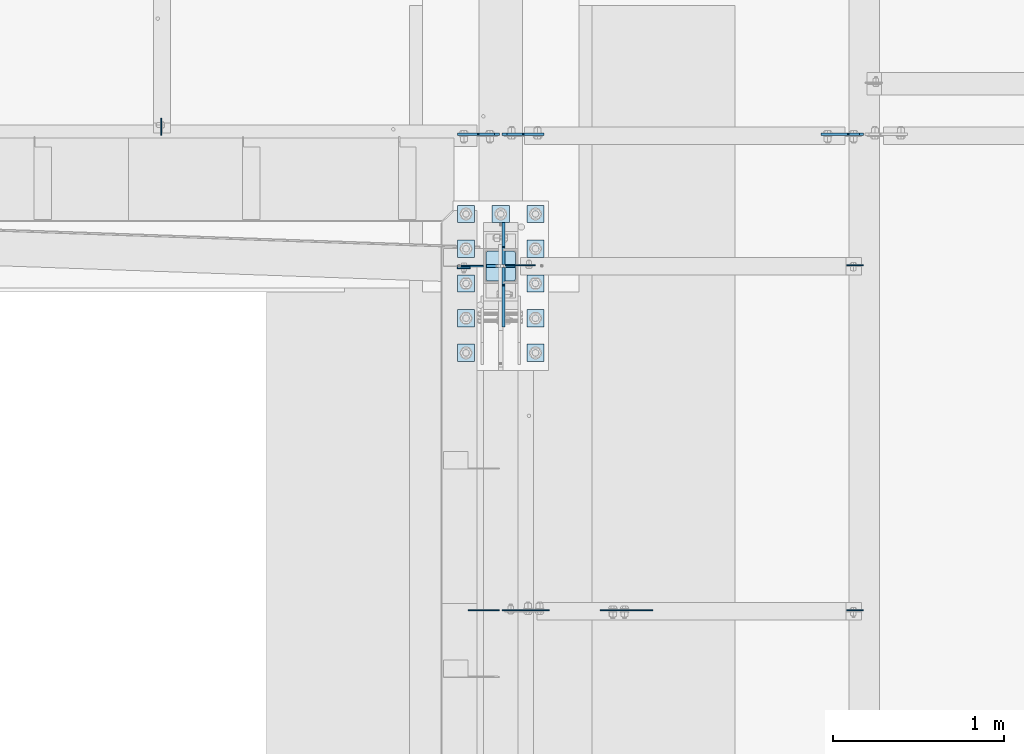
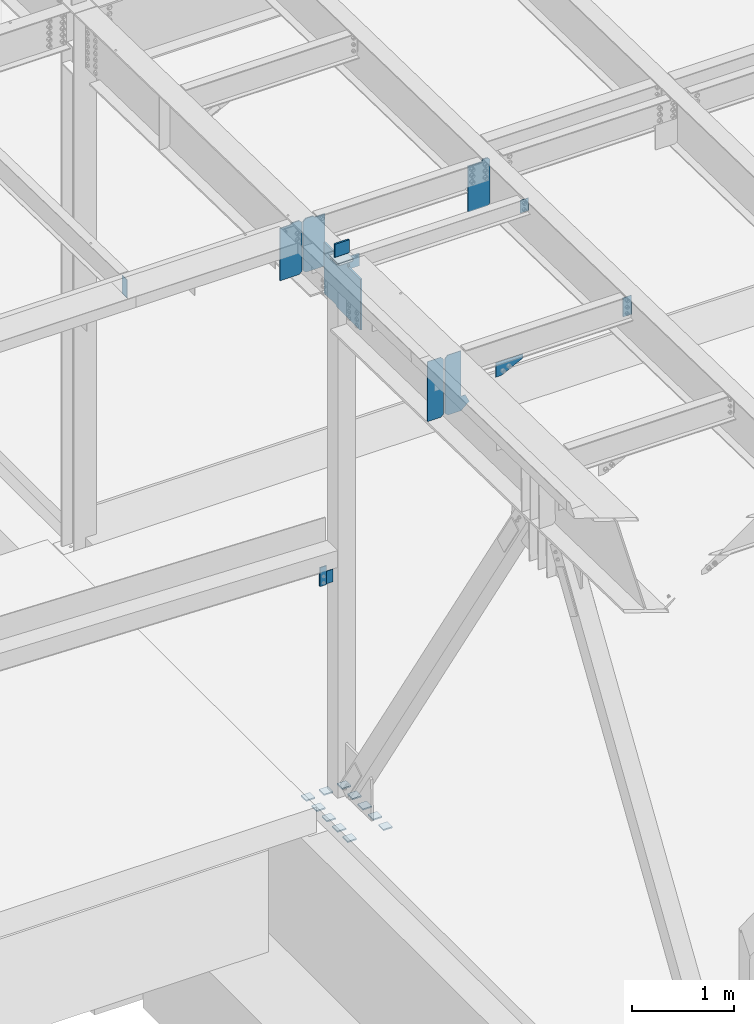
# One storey, part 1437 of 1763: 26 plates, 8 elements without a shape of their own.
"""IFC2X3 building model written with IfcOpenShell, lengths in millimetres."""

from ifc_helpers import new_model, si_unit, frame, origin_with_axes, place, context, subcontext, project, spatial, faceted_brep, material, type_object, element, aggregate, save


model = new_model("IFC2X3")

# Units and contexts
model_context = context("Model", 3, precision=1e-05, world=origin_with_axes())
body_context = subcontext(model_context, "Body", "Model", "MODEL_VIEW")
ifc_project = project(units=[si_unit("LENGTHUNIT", "METRE", prefix="MILLI"), si_unit("AREAUNIT", "SQUARE_METRE"), si_unit("VOLUMEUNIT", "CUBIC_METRE"), si_unit("MASSUNIT", "GRAM", prefix="KILO"), si_unit("TIMEUNIT", "SECOND"), si_unit("PLANEANGLEUNIT", "RADIAN"), si_unit("SOLIDANGLEUNIT", "STERADIAN"), si_unit("THERMODYNAMICTEMPERATUREUNIT", "DEGREE_CELSIUS"), si_unit("LUMINOUSINTENSITYUNIT", "LUMEN")], contexts=[model_context])

# Site, building, storey
site_placement = place(None, origin_with_axes())
site = spatial("IfcSite", under=ifc_project, at=site_placement, CompositionType="ELEMENT")
building_placement = place(site_placement, origin_with_axes())
building = spatial("IfcBuilding", under=site, at=building_placement, Name="Undefined", CompositionType="ELEMENT")
storey_placement = place(building_placement, origin_with_axes())
storey = spatial("IfcBuildingStorey", under=building, at=storey_placement, Name="Undefined", CompositionType="ELEMENT", Elevation=0.0)

# Assembly, plates
assembly_1_placement = place(storey_placement, origin_with_axes())
assembly_1 = element("IfcElementAssembly", 1, at=assembly_1_placement, inside=storey, Name="BEAM", AssemblyPlace="NOTDEFINED", PredefinedType="RIGID_FRAME")
ifc_material_1 = material(Name="STEEL/A36")
plate_type_1 = type_object("IfcPlateType", PredefinedType="NOTDEFINED")
plate_1_placement = place(assembly_1_placement, frame((-85253.8569165555, 8539.95625000002, 11685.5045365056), z_axis=(-1.0, 0.0, 0.0), x_axis=(0.0, 0.0, -1.0)))
plate_1 = element("IfcPlate", 2, at=plate_1_placement, type_object=plate_type_1, material=ifc_material_1, Name="PLATE", context=body_context, shape_type="Brep", body=[
    faceted_brep([(1.81898940354586e-12, -3.17500000000291, 0.0), (0.0, -3.17499999999927, 96.8375015258789), (0.0, 3.17499999999927, 96.8375015258789), (-1.81898940354586e-12, 3.17499999997381, 0.0), (152.399993896484, -3.17499999999927, 96.8375015258789), (152.399993896484, 3.17499999999927, 96.8375015258789), (152.399993896484, -3.17500000000291, 0.0), (152.399993896484, 3.17500000000291, 0.0)], [[[0, 1, 2, 3]], [[1, 4, 5, 2]], [[4, 6, 7, 5]], [[6, 0, 3, 7]], [[5, 7, 3, 2]], [[6, 4, 1, 0]]]),
])
plate_2_placement = place(assembly_1_placement, frame((-85253.8569165555, 6521.44999998666, 11743.6501802739), z_axis=(-1.0, 0.0, 0.0), x_axis=(0.0, 0.0, -1.0)))
plate_2 = element("IfcPlate", 3, at=plate_2_placement, type_object=plate_type_1, material=ifc_material_1, Name="PLATE", context=body_context, shape_type="Brep", body=[
    faceted_brep([(1.81898940354586e-12, -3.17500000000291, 0.0), (0.0, -3.17499999999927, 96.8375015258789), (0.0, 3.17499999999927, 96.8375015258789), (-1.81898940354586e-12, 3.17499999997381, 0.0), (228.600006103516, -3.17499999999927, 96.8375015258789), (228.600006103516, 3.17499999999927, 96.8375015258789), (228.600006103516, -3.17500000001019, -7.27595761418343e-12), (228.600006103516, 3.17499999999563, -7.27595761418343e-12)], [[[0, 1, 2, 3]], [[1, 4, 5, 2]], [[4, 6, 7, 5]], [[6, 0, 3, 7]], [[5, 7, 3, 2]], [[6, 4, 1, 0]]]),
])

# Assembly, plate
assembly_2_placement = place(storey_placement, origin_with_axes())
assembly_2 = element("IfcElementAssembly", 4, at=assembly_2_placement, inside=storey, Name="BEAM", AssemblyPlace="NOTDEFINED", PredefinedType="RIGID_FRAME")
plate_type_2 = type_object("IfcPlateType", PredefinedType="NOTDEFINED")
plate_3_placement = place(assembly_2_placement, frame((-87553.2372858673, 8524.87499837763, 8096.24999389648), z_axis=(0.0, 0.0, -1.0), x_axis=(-1.0, 0.0, 0.0)))
plate_3 = element("IfcPlate", 5, at=plate_3_placement, type_object=plate_type_2, material=ifc_material_1, Name="PLATE", context=body_context, shape_type="Brep", body=[
    faceted_brep([(0.0, -4.76249999999982, 0.0), (-2.83762346953154e-10, -4.7624999996915, 228.600006103516), (-2.83762346953154e-10, 4.76250000028813, 228.600006103517), (0.0, 4.76249999999982, 0.0), (76.1999969480166, -4.76249999961874, 228.600006103516), (76.1999969480166, 4.76250000036089, 228.600006103517), (76.1999969482931, -4.76249999991705, 0.0), (76.1999969482931, 4.76250000006257, 1.81898940354586e-12)], [[[0, 1, 2, 3]], [[1, 4, 5, 2]], [[4, 6, 7, 5]], [[6, 0, 3, 7]], [[5, 7, 3, 2]], [[6, 4, 1, 0]]]),
])
aggregate(assembly_2, [plate_3])

assembly_3_placement = place(storey_placement, origin_with_axes())
assembly_3 = element("IfcElementAssembly", 6, at=assembly_3_placement, inside=storey, Name="COLUMN", AssemblyPlace="NOTDEFINED", PredefinedType="RIGID_FRAME")
plate_type_3 = type_object("IfcPlateType", PredefinedType="NOTDEFINED")
plate_4_placement = place(assembly_3_placement, frame((-87629.4372828536, 8534.39999695398, 7867.64998779296), z_axis=(0.0, 0.0, 1.0), x_axis=(1.0, 0.0, 0.0)))
plate_4 = element("IfcPlate", 7, at=plate_4_placement, type_object=plate_type_3, material=ifc_material_1, Name="PLATE", context=body_context, shape_type="Brep", body=[
    faceted_brep([(0.0, -4.76249999999982, 0.0), (-3.05175672110636e-06, -4.7625000002663, 152.399993896484), (-3.05175490211695e-06, 4.76249999972788, 152.399993896484), (0.0, 4.76249999999982, 0.0), (152.400009155272, -4.76249999975698, 152.399993896484), (152.400009155273, 4.76250000024447, 152.399993896484), (152.400009155272, -4.76249999948777, 5.45696821063757e-12), (152.400009155273, 4.76250000051368, 3.63797880709171e-12)], [[[0, 1, 2, 3]], [[1, 4, 5, 2]], [[4, 6, 7, 5]], [[6, 0, 3, 7]], [[5, 7, 3, 2]], [[6, 4, 1, 0]]]),
])

# Assembly, plates
assembly_4_placement = place(storey_placement, origin_with_axes())
assembly_4 = element("IfcElementAssembly", 8, at=assembly_4_placement, inside=storey, Name="TEMPLATE", AssemblyPlace="NOTDEFINED", PredefinedType="RIGID_FRAME")
plate_type_4 = type_object("IfcPlateType", PredefinedType="NOTDEFINED")
plate_5_placement = place(assembly_4_placement, frame((-87527.8372736983, 8077.20000000001, 5138.73750000001), z_axis=(-1.0, 0.0, 0.0), x_axis=(0.0, -1.0, 0.0)))
plate_5 = element("IfcPlate", 9, at=plate_5_placement, type_object=plate_type_4, material=ifc_material_1, Name="WASHER PLATE", context=body_context, shape_type="Brep", body=[
    faceted_brep([(-7.27595761418343e-12, -7.9375, 0.0), (0.0, -7.9375, 101.599998474121), (0.0, 7.9375, 101.599998474121), (-7.27595761418343e-12, 7.9375, 0.0), (101.599998474121, -7.9375, 101.599998474121), (101.599998474121, 7.9375, 101.599998474121), (101.599998474121, -7.9375, 0.0), (101.599998474121, 7.9375, 0.0)], [[[0, 1, 2, 3]], [[1, 4, 5, 2]], [[4, 6, 7, 5]], [[6, 0, 3, 7]], [[5, 7, 3, 2]], [[6, 4, 1, 0]]]),
])
plate_6_placement = place(assembly_4_placement, frame((-87121.4372736983, 8077.20000000001, 5138.73750000001), z_axis=(-1.0, 0.0, 0.0), x_axis=(0.0, -1.0, 0.0)))
plate_6 = element("IfcPlate", 10, at=plate_6_placement, type_object=plate_type_4, material=ifc_material_1, Name="WASHER PLATE", context=body_context, shape_type="Brep", body=[
    faceted_brep([(-7.27595761418343e-12, -7.9375, 0.0), (0.0, -7.9375, 101.599998474121), (0.0, 7.9375, 101.599998474121), (-7.27595761418343e-12, 7.9375, 0.0), (101.599998474121, -7.9375, 101.599998474121), (101.599998474121, 7.9375, 101.599998474121), (101.599998474121, -7.9375, 0.0), (101.599998474121, 7.9375, 0.0)], [[[0, 1, 2, 3]], [[1, 4, 5, 2]], [[4, 6, 7, 5]], [[6, 0, 3, 7]], [[5, 7, 3, 2]], [[6, 4, 1, 0]]]),
])
plate_7_placement = place(assembly_4_placement, frame((-87527.8372736983, 8280.40000000001, 5138.73750000001), z_axis=(-1.0, 0.0, 0.0), x_axis=(0.0, -1.0, 0.0)))
plate_7 = element("IfcPlate", 11, at=plate_7_placement, type_object=plate_type_4, material=ifc_material_1, Name="WASHER PLATE", context=body_context, shape_type="Brep", body=[
    faceted_brep([(-7.27595761418343e-12, -7.9375, 0.0), (0.0, -7.9375, 101.599998474121), (0.0, 7.9375, 101.599998474121), (-7.27595761418343e-12, 7.9375, 0.0), (101.599998474121, -7.9375, 101.599998474121), (101.599998474121, 7.9375, 101.599998474121), (101.599998474121, -7.9375, 0.0), (101.599998474121, 7.9375, 0.0)], [[[0, 1, 2, 3]], [[1, 4, 5, 2]], [[4, 6, 7, 5]], [[6, 0, 3, 7]], [[5, 7, 3, 2]], [[6, 4, 1, 0]]]),
])
plate_8_placement = place(assembly_4_placement, frame((-87121.4372736983, 8280.40000000001, 5138.73750000001), z_axis=(-1.0, 0.0, 0.0), x_axis=(0.0, -1.0, 0.0)))
plate_8 = element("IfcPlate", 12, at=plate_8_placement, type_object=plate_type_4, material=ifc_material_1, Name="WASHER PLATE", context=body_context, shape_type="Brep", body=[
    faceted_brep([(-7.27595761418343e-12, -7.9375, 0.0), (0.0, -7.9375, 101.599998474121), (0.0, 7.9375, 101.599998474121), (-7.27595761418343e-12, 7.9375, 0.0), (101.599998474121, -7.9375, 101.599998474121), (101.599998474121, 7.9375, 101.599998474121), (101.599998474121, -7.9375, 0.0), (101.599998474121, 7.9375, 0.0)], [[[0, 1, 2, 3]], [[1, 4, 5, 2]], [[4, 6, 7, 5]], [[6, 0, 3, 7]], [[5, 7, 3, 2]], [[6, 4, 1, 0]]]),
])
plate_9_placement = place(assembly_4_placement, frame((-87527.8372736983, 8483.60000000001, 5138.73750000001), z_axis=(-1.0, 0.0, 0.0), x_axis=(0.0, -1.0, 0.0)))
plate_9 = element("IfcPlate", 13, at=plate_9_placement, type_object=plate_type_4, material=ifc_material_1, Name="WASHER PLATE", context=body_context, shape_type="Brep", body=[
    faceted_brep([(-7.27595761418343e-12, -7.9375, 0.0), (0.0, -7.9375, 101.599998474121), (0.0, 7.9375, 101.599998474121), (-7.27595761418343e-12, 7.9375, 0.0), (101.599998474121, -7.9375, 101.599998474121), (101.599998474121, 7.9375, 101.599998474121), (101.599998474121, -7.9375, 0.0), (101.599998474121, 7.9375, 0.0)], [[[0, 1, 2, 3]], [[1, 4, 5, 2]], [[4, 6, 7, 5]], [[6, 0, 3, 7]], [[5, 7, 3, 2]], [[6, 4, 1, 0]]]),
])
plate_10_placement = place(assembly_4_placement, frame((-87121.4372736983, 8483.60000000001, 5138.73750000001), z_axis=(-1.0, 0.0, 0.0), x_axis=(0.0, -1.0, 0.0)))
plate_10 = element("IfcPlate", 14, at=plate_10_placement, type_object=plate_type_4, material=ifc_material_1, Name="WASHER PLATE", context=body_context, shape_type="Brep", body=[
    faceted_brep([(-7.27595761418343e-12, -7.9375, 0.0), (0.0, -7.9375, 101.599998474121), (0.0, 7.9375, 101.599998474121), (-7.27595761418343e-12, 7.9375, 0.0), (101.599998474121, -7.9375, 101.599998474121), (101.599998474121, 7.9375, 101.599998474121), (101.599998474121, -7.9375, 0.0), (101.599998474121, 7.9375, 0.0)], [[[0, 1, 2, 3]], [[1, 4, 5, 2]], [[4, 6, 7, 5]], [[6, 0, 3, 7]], [[5, 7, 3, 2]], [[6, 4, 1, 0]]]),
])
plate_11_placement = place(assembly_4_placement, frame((-87527.8372736983, 8686.80000000001, 5138.73750000001), z_axis=(-1.0, 0.0, 0.0), x_axis=(0.0, -1.0, 0.0)))
plate_11 = element("IfcPlate", 15, at=plate_11_placement, type_object=plate_type_4, material=ifc_material_1, Name="WASHER PLATE", context=body_context, shape_type="Brep", body=[
    faceted_brep([(-7.27595761418343e-12, -7.9375, 0.0), (0.0, -7.9375, 101.599998474121), (0.0, 7.9375, 101.599998474121), (-7.27595761418343e-12, 7.9375, 0.0), (101.599998474121, -7.9375, 101.599998474121), (101.599998474121, 7.9375, 101.599998474121), (101.599998474121, -7.9375, 0.0), (101.599998474121, 7.9375, 0.0)], [[[0, 1, 2, 3]], [[1, 4, 5, 2]], [[4, 6, 7, 5]], [[6, 0, 3, 7]], [[5, 7, 3, 2]], [[6, 4, 1, 0]]]),
])
plate_12_placement = place(assembly_4_placement, frame((-87121.4372736983, 8686.80000000001, 5138.73750000001), z_axis=(-1.0, 0.0, 0.0), x_axis=(0.0, -1.0, 0.0)))
plate_12 = element("IfcPlate", 16, at=plate_12_placement, type_object=plate_type_4, material=ifc_material_1, Name="WASHER PLATE", context=body_context, shape_type="Brep", body=[
    faceted_brep([(-7.27595761418343e-12, -7.9375, 0.0), (0.0, -7.9375, 101.599998474121), (0.0, 7.9375, 101.599998474121), (-7.27595761418343e-12, 7.9375, 0.0), (101.599998474121, -7.9375, 101.599998474121), (101.599998474121, 7.9375, 101.599998474121), (101.599998474121, -7.9375, 0.0), (101.599998474121, 7.9375, 0.0)], [[[0, 1, 2, 3]], [[1, 4, 5, 2]], [[4, 6, 7, 5]], [[6, 0, 3, 7]], [[5, 7, 3, 2]], [[6, 4, 1, 0]]]),
])
plate_13_placement = place(assembly_4_placement, frame((-87527.8372736983, 8890.00000000001, 5138.73750000001), z_axis=(-1.0, 0.0, 0.0), x_axis=(0.0, -1.0, 0.0)))
plate_13 = element("IfcPlate", 17, at=plate_13_placement, type_object=plate_type_4, material=ifc_material_1, Name="WASHER PLATE", context=body_context, shape_type="Brep", body=[
    faceted_brep([(-7.27595761418343e-12, -7.9375, 0.0), (0.0, -7.9375, 101.599998474121), (0.0, 7.9375, 101.599998474121), (-7.27595761418343e-12, 7.9375, 0.0), (101.599998474121, -7.9375, 101.599998474121), (101.599998474121, 7.9375, 101.599998474121), (101.599998474121, -7.9375, 0.0), (101.599998474121, 7.9375, 0.0)], [[[0, 1, 2, 3]], [[1, 4, 5, 2]], [[4, 6, 7, 5]], [[6, 0, 3, 7]], [[5, 7, 3, 2]], [[6, 4, 1, 0]]]),
])
plate_14_placement = place(assembly_4_placement, frame((-87324.6372736983, 8890.00000000001, 5138.73750000001), z_axis=(-1.0, 0.0, 0.0), x_axis=(0.0, -1.0, 0.0)))
plate_14 = element("IfcPlate", 18, at=plate_14_placement, type_object=plate_type_4, material=ifc_material_1, Name="WASHER PLATE", context=body_context, shape_type="Brep", body=[
    faceted_brep([(-7.27595761418343e-12, -7.9375, 0.0), (0.0, -7.9375, 101.599998474121), (0.0, 7.9375, 101.599998474121), (-7.27595761418343e-12, 7.9375, 0.0), (101.599998474121, -7.9375, 101.599998474121), (101.599998474121, 7.9375, 101.599998474121), (101.599998474121, -7.9375, 0.0), (101.599998474121, 7.9375, 0.0)], [[[0, 1, 2, 3]], [[1, 4, 5, 2]], [[4, 6, 7, 5]], [[6, 0, 3, 7]], [[5, 7, 3, 2]], [[6, 4, 1, 0]]]),
])
plate_15_placement = place(assembly_4_placement, frame((-87121.4372736983, 8890.00000000001, 5138.73750000001), z_axis=(-1.0, 0.0, 0.0), x_axis=(0.0, -1.0, 0.0)))
plate_15 = element("IfcPlate", 19, at=plate_15_placement, type_object=plate_type_4, material=ifc_material_1, Name="WASHER PLATE", context=body_context, shape_type="Brep", body=[
    faceted_brep([(-7.27595761418343e-12, -7.9375, 0.0), (0.0, -7.9375, 101.599998474121), (0.0, 7.9375, 101.599998474121), (-7.27595761418343e-12, 7.9375, 0.0), (101.599998474121, -7.9375, 101.599998474121), (101.599998474121, 7.9375, 101.599998474121), (101.599998474121, -7.9375, 0.0), (101.599998474121, 7.9375, 0.0)], [[[0, 1, 2, 3]], [[1, 4, 5, 2]], [[4, 6, 7, 5]], [[6, 0, 3, 7]], [[5, 7, 3, 2]], [[6, 4, 1, 0]]]),
])
aggregate(assembly_4, [plate_5, plate_6, plate_7, plate_8, plate_9, plate_10, plate_11, plate_12, plate_13, plate_14, plate_15])

# Plate
ifc_material_2 = material(Name="STEEL/A572-50")
plate_type_5 = type_object("IfcPlateType", PredefinedType="NOTDEFINED")
plate_16_placement = place(assembly_3_placement, frame((-87292.8872736984, 8534.40000000001, 11904.6348438825), z_axis=(0.0, 0.0, -1.0), x_axis=(-1.0, 0.0, 0.0)))
plate_16 = element("IfcPlate", 20, at=plate_16_placement, type_object=plate_type_5, material=ifc_material_2, Name="PLATE", context=body_context, shape_type="Brep", body=[
    faceted_brep([(7.27595761418343e-12, 9.52500000000146, 155.574990844727), (-1.45519152283669e-11, 7.27595761418343e-12, 165.099990844727), (165.099990844727, 0.0, 165.099990844727), (165.099990844727, 9.52500000000146, 155.574990844727), (-3.63797880709171e-11, -9.5249999999869, 155.574990844727), (165.099990844727, -9.52500000000146, 155.574990844727), (0.0, 9.52500000000146, 0.0), (0.0, -9.52500000000146, 0.0), (165.099990844727, -9.52500000000146, 0.0), (165.099990844727, 9.52500000000146, 0.0)], [[[0, 1, 2, 3]], [[1, 4, 5, 2]], [[6, 7, 4, 1, 0]], [[5, 8, 9, 3, 2]], [[8, 7, 6, 9]], [[9, 6, 0, 3]], [[7, 8, 5, 4]]]),
])

# Assembly, plate
assembly_5_placement = place(storey_placement, origin_with_axes())
assembly_5 = element("IfcElementAssembly", 21, at=assembly_5_placement, inside=storey, Name="BEAM", AssemblyPlace="NOTDEFINED", PredefinedType="RIGID_FRAME")
plate_type_6 = type_object("IfcPlateType", PredefinedType="NOTDEFINED")
plate_17_placement = place(assembly_5_placement, frame((-89362.1935236984, 9299.575, 11677.8342065501), z_axis=(0.0, 1.0, 0.0), x_axis=(0.0, 0.0, -1.0)))
plate_17 = element("IfcPlate", 22, at=plate_17_placement, type_object=plate_type_6, material=ifc_material_1, Name="PLATE", context=body_context, shape_type="Brep", body=[
    faceted_brep([(1.81898940354586e-12, -3.17500000000291, 0.0), (-2.52839527092874e-10, -3.17500000000001, 98.4250000002357), (4.17785486206412e-08, 3.17500000000001, 98.425000000243), (-1.81898940354586e-12, 3.17499999997381, 0.0), (215.899993896484, -3.17500000000291, 98.4250030517578), (215.899993896484, 3.17500000000291, 98.4250030517578), (215.899993896484, -3.17500000000291, 0.0), (215.899993896484, 3.17500000000291, 0.0)], [[[0, 1, 2, 3]], [[1, 4, 5, 2]], [[4, 6, 7, 5]], [[6, 0, 3, 7]], [[5, 7, 3, 2]], [[6, 4, 1, 0]]]),
])
aggregate(assembly_5, [plate_17])

# Assembly, plates
assembly_6_placement = place(storey_placement, origin_with_axes())
assembly_6 = element("IfcElementAssembly", 23, at=assembly_6_placement, inside=storey, Name="BEAM", AssemblyPlace="NOTDEFINED", PredefinedType="RIGID_FRAME")
plate_type_7 = type_object("IfcPlateType", PredefinedType="NOTDEFINED")
plate_18_placement = place(assembly_6_placement, frame((-87383.6747736984, 6521.45000003568, 11035.6954250997), z_axis=(0.0, 0.0, 1.0), x_axis=(-1.0, 0.0, 0.0)))
plate_18 = element("IfcPlate", 24, at=plate_18_placement, type_object=plate_type_7, material=ifc_material_1, Name="PLATE", context=body_context, shape_type="Brep", body=[
    faceted_brep([(0.0, -3.17500000000291, 31.75), (0.0, -3.17499999999927, 686.812194824219), (0.0, 3.17499999999927, 686.812194824219), (0.0, 3.17500000000291, 31.75), (31.75, -3.17499999999927, 718.562194824219), (31.75, 3.17499999999927, 718.562194824219), (182.5625, -3.17499999999927, 718.562194824219), (182.5625, 3.17499999999927, 718.562194824219), (182.5625, -3.17500000000291, 0.0), (182.5625, 3.17500000000291, 0.0), (31.7499999999036, -3.17499999997381, 9.42916855706244e-11), (31.7499999998854, 3.17500000000291, 9.42916855706244e-11)], [[[0, 1, 2, 3]], [[1, 4, 5, 2]], [[4, 6, 7, 5]], [[6, 8, 9, 7]], [[8, 10, 11, 9]], [[10, 0, 3, 11]], [[5, 7, 9, 11, 3, 2]], [[10, 8, 6, 4, 1, 0]]]),
])
plate_type_8 = type_object("IfcPlateType", PredefinedType="NOTDEFINED")
plate_19_placement = place(assembly_6_placement, frame((-87367.1997736983, 6521.4500000346, 11035.6954250997), z_axis=(0.0, 0.0, 1.0), x_axis=(1.0, 0.0, 0.0)))
plate_19 = element("IfcPlate", 25, at=plate_19_placement, type_object=plate_type_8, material=ifc_material_1, Name="PLATE", context=body_context, shape_type="Brep", body=[
    faceted_brep([(0.0, -3.17500000000291, 31.75), (0.0, -3.17499999999927, 686.812255859375), (0.0, 3.17499999999927, 686.812255859375), (0.0, 3.17500000000291, 31.75), (31.75, -3.17499999999927, 718.562255859375), (31.75, 3.17499999999927, 718.562255859375), (182.5625, -3.17500000000018, 718.562255859375), (182.5625, 3.17500000000018, 718.562255859375), (182.261993408203, -3.17499999999927, 172.454345703125), (182.261993408203, 3.17499999999927, 172.454345703125), (230.306228637695, -3.17499999999927, 172.454345703125), (230.306228637695, 3.17499999999927, 172.454345703125), (275.743133544922, -3.17499999999927, 81.5805358886719), (275.743133544922, 3.17499999999927, 81.5805358886719), (182.262496948242, -3.17500000000018, 0.0), (182.262496948242, 3.17500000000018, 0.0), (31.7499999999036, -3.17499999997381, 9.42916855706244e-11), (31.7499999998854, 3.17500000000291, 9.42916855706244e-11)], [[[0, 1, 2, 3]], [[1, 4, 5, 2]], [[4, 6, 7, 5]], [[6, 8, 9, 7]], [[8, 10, 11, 9]], [[10, 12, 13, 11]], [[12, 14, 15, 13]], [[14, 16, 17, 15]], [[16, 0, 3, 17]], [[5, 7, 9, 11, 13, 15, 17, 3, 2]], [[16, 14, 12, 10, 8, 6, 4, 1, 0]]]),
])
aggregate(assembly_6, [plate_18, plate_19])

# Assembly, plate
assembly_7_placement = place(storey_placement, origin_with_axes())
assembly_7 = element("IfcElementAssembly", 26, at=assembly_7_placement, inside=storey, Name="BEAM", AssemblyPlace="NOTDEFINED", PredefinedType="RIGID_FRAME")
plate_type_9 = type_object("IfcPlateType", PredefinedType="NOTDEFINED")
plate_20_placement = place(assembly_7_placement, frame((-86792.4786752764, 6521.44999998672, 11470.6001802778), z_axis=(1.0, 0.0, 0.0), x_axis=(0.0, 0.0, -1.0)))
plate_20 = element("IfcPlate", 27, at=plate_20_placement, type_object=plate_type_9, material=ifc_material_1, Name="PLATE", context=body_context, shape_type="Brep", body=[
    faceted_brep([(1.81898940354586e-12, -3.17500000000291, 0.0), (0.0, -3.17499999999927, 306.070465087891), (0.0, 3.17499999999927, 306.070465087891), (-1.81898940354586e-12, 3.17499999997381, 0.0), (50.7999992370605, -3.17499999999927, 306.070465087891), (50.7999992370605, 3.17499999999927, 306.070465087891), (172.922760009766, -3.17499999999927, 61.8249359130859), (172.922760009766, 3.17499999999927, 61.8249359130859), (172.922760009766, -3.17499999999927, 0.0), (172.922760009766, 3.17499999999927, 0.0)], [[[0, 1, 2, 3]], [[1, 4, 5, 2]], [[4, 6, 7, 5]], [[6, 8, 9, 7]], [[8, 0, 3, 9]], [[5, 7, 9, 3, 2]], [[8, 6, 4, 1, 0]]]),
])
aggregate(assembly_7, [plate_20])

# Plate
plate_type_10 = type_object("IfcPlateType", PredefinedType="NOTDEFINED")
plate_21_placement = place(assembly_3_placement, frame((-87288.1247736983, 8621.71250000001, 11707.7848499861), z_axis=(0.0, -1.0, 0.0), x_axis=(-1.0, 0.0, 0.0)))
plate_21 = element("IfcPlate", 28, at=plate_21_placement, type_object=plate_type_10, material=ifc_material_1, Name="PLATE", context=body_context, shape_type="Brep", body=[
    faceted_brep([(-2.18278728425503e-11, -12.7000000000007, 15.875), (0.0, -12.7000000000007, 158.75), (0.0, 12.7000000000007, 158.75), (-2.18278728425503e-11, 12.7000000000007, 15.875), (1.20841242138704, -12.7000000000007, 164.825099488797), (1.20841242138704, 12.7000000000007, 164.825099488797), (4.6496798486769, -12.7000000000007, 169.975320151338), (4.6496798486769, 12.7000000000007, 169.975320151338), (9.79990051120694, -12.7000000000007, 173.416587578617), (9.79990051120694, 12.7000000000007, 173.416587578617), (15.875, -12.7000000000007, 174.625), (15.875, 12.7000000000007, 174.625), (158.75, -12.7000000000007, 174.625), (158.75, 12.7000000000007, 174.625), (164.825099488793, -12.7000000000007, 173.416587578617), (164.825099488793, 12.7000000000007, 173.416587578617), (169.975320151338, -12.7000000000007, 169.975320151336), (169.975320151338, 12.7000000000007, 169.975320151336), (173.416587578613, -12.7000000000007, 164.825099488797), (173.416587578613, 12.7000000000007, 164.825099488797), (174.625, -12.7000000000007, 158.75), (174.625, 12.7000000000007, 158.75), (174.625, -12.7000000000007, 15.8750000000073), (174.625, 12.7000000000007, 15.8750000000073), (173.416587578613, -12.7000000000007, 9.79990051121058), (173.416587578613, 12.7000000000007, 9.79990051121058), (169.975320151338, -12.7000000000007, 4.64967984866962), (169.975320151338, 12.7000000000007, 4.64967984866962), (164.825099488793, -12.7000000000007, 1.20841242139068), (164.825099488793, 12.7000000000007, 1.20841242139068), (158.75, -12.7000000000007, 7.27595761418343e-12), (158.75, 12.7000000000007, 7.27595761418343e-12), (15.8749999999854, -12.7000000000007, 0.0), (15.8749999999854, 12.7000000000007, 0.0), (9.79990051119239, -12.7000000000007, 1.20841242137976), (9.79990051119239, 12.7000000000007, 1.20841242137976), (4.64967984864779, -12.7000000000007, 4.64967984866234), (4.64967984864779, 12.7000000000007, 4.64967984866234), (1.20841242136521, -12.7000000000007, 9.79990051119967), (1.20841242136521, 12.7000000000007, 9.79990051119967)], [[[0, 1, 2, 3]], [[1, 4, 5, 2]], [[4, 6, 7, 5]], [[6, 8, 9, 7]], [[8, 10, 11, 9]], [[10, 12, 13, 11]], [[12, 14, 15, 13]], [[14, 16, 17, 15]], [[16, 18, 19, 17]], [[18, 20, 21, 19]], [[20, 22, 23, 21]], [[22, 24, 25, 23]], [[24, 26, 27, 25]], [[26, 28, 29, 27]], [[28, 30, 31, 29]], [[30, 32, 33, 31]], [[32, 34, 35, 33]], [[34, 36, 37, 35]], [[36, 38, 39, 37]], [[38, 0, 3, 39]], [[5, 7, 9, 11, 13, 15, 17, 19, 21, 23, 25, 27, 29, 31, 33, 35, 37, 39, 3, 2]], [[38, 36, 34, 32, 30, 28, 26, 24, 22, 20, 18, 16, 14, 12, 10, 8, 6, 4, 1, 0]]]),
])

plate_type_11 = type_object("IfcPlateType", PredefinedType="NOTDEFINED")
plate_22_placement = place(assembly_3_placement, frame((-87273.8372736983, 8539.95625, 11695.0295365109), z_axis=(0.0, 0.0, -1.0), x_axis=(-1.0, 0.0, 0.0)))
plate_22 = element("IfcPlate", 29, at=plate_22_placement, type_object=plate_type_11, material=ifc_material_1, Name="PLATE", context=body_context, shape_type="Brep", body=[
    faceted_brep([(1.81898940354586e-12, -3.17500000000291, 0.0), (-101.599998474121, -3.17499999999927, 0.0), (-101.599998474121, 3.17499999999927, 0.0), (-1.81898940354586e-12, 3.17499999997381, 0.0), (-101.599998474121, -3.17499999999927, 152.399993896484), (-101.599998474121, 3.17499999999927, 152.399993896484), (76.1999969482422, -3.17499999999927, 152.399993896484), (76.1999969482422, 3.17499999999927, 152.399993896484), (76.1999969482422, -3.17500000000291, 0.0), (76.1999969482422, 3.17500000000291, 0.0)], [[[0, 1, 2, 3]], [[1, 4, 5, 2]], [[4, 6, 7, 5]], [[6, 8, 9, 7]], [[8, 0, 3, 9]], [[5, 7, 9, 3, 2]], [[8, 6, 4, 1, 0]]]),
])

# Assembly, plate
assembly_8_placement = place(storey_placement, origin_with_axes())
assembly_8 = element("IfcElementAssembly", 30, at=assembly_8_placement, inside=storey, Name="BEAM", AssemblyPlace="NOTDEFINED", PredefinedType="RIGID_FRAME")
plate_type_12 = type_object("IfcPlateType", PredefinedType="NOTDEFINED")
plate_23_placement = place(assembly_8_placement, frame((-87368.7872736984, 9305.92500000067, 11060.1181657913), z_axis=(0.0, 0.0, 1.0), x_axis=(1.0, 0.0, 0.0)))
plate_23 = element("IfcPlate", 31, at=plate_23_placement, type_object=plate_type_12, material=ifc_material_2, Name="PLATE", context=body_context, shape_type="Brep", body=[
    faceted_brep([(120.349998474121, -6.34999999999854, 643.800354003906), (120.349998474121, -6.35000000000036, 638.086370528727), (120.349998474121, 6.35000000000036, 638.086370528727), (120.349998474121, 6.34999999999854, 643.800354003906), (121.316728396705, -6.35000000000036, 633.22629101068), (121.316728396705, 6.35000000000036, 633.22629101068), (124.069742297186, -6.35000000000036, 629.106114542526), (124.069742297186, 6.35000000000036, 629.106114542526), (128.189918765347, -6.35000000000036, 626.353100642049), (128.189918765347, 6.35000000000036, 626.353100642049), (133.049998283386, -6.35000000000036, 625.386370719461), (133.049998283386, 6.35000000000036, 625.386370719461), (247.649993896484, -6.35000000000036, 625.386370719461), (247.649993896484, 6.35000000000036, 625.386370719461), (0.0, -6.34999999999854, 613.637853622437), (30.1625003814697, -6.34999999999854, 643.800354003906), (30.1625003814697, 6.34999999999854, 643.800354003906), (0.0, 6.34999999999854, 613.637853622437), (0.0, -6.34999999999854, 30.1625003814697), (0.0, 6.34999999999854, 30.1625003814697), (30.1625003814697, -6.34999999999854, 0.0), (30.1625003814697, 6.34999999999854, 0.0), (247.649993896484, -6.34999999999854, 0.0), (247.649993896484, 6.34999999999854, 0.0)], [[[0, 1, 2, 3]], [[4, 5, 2, 1]], [[6, 7, 5, 4]], [[8, 9, 7, 6]], [[10, 11, 9, 8]], [[12, 13, 11, 10]], [[14, 15, 16, 17]], [[18, 14, 17, 19]], [[20, 18, 19, 21]], [[22, 20, 21, 23]], [[8, 6, 4, 1, 0, 15, 14, 18, 20, 22, 12, 10]], [[16, 15, 0, 3]], [[23, 21, 19, 17, 16, 3, 2, 5, 7, 9, 11, 13]], [[22, 23, 13, 12]]]),
])

# Plate
plate_24_placement = place(assembly_1_placement, frame((-85254.1569165555, 9305.92500001422, 11136.3348158672), z_axis=(0.0, 0.0, 1.0), x_axis=(-1.0, 0.0, 0.0)))
plate_24 = element("IfcPlate", 32, at=plate_24_placement, type_object=plate_type_12, material=ifc_material_2, Name="PLATE", context=body_context, shape_type="Brep", body=[
    faceted_brep([(83.8374938964844, -6.35000000000036, 573.93505859375), (83.8374938964844, -6.35000000000036, 561.869720450019), (83.8374938964844, 6.35000000000036, 561.869720450019), (83.8374938964844, 6.35000000000036, 573.93505859375), (84.8042238190683, -6.35000000000036, 557.009640931972), (84.8042238190683, 6.35000000000036, 557.009640931972), (87.5572377195494, -6.35000000000036, 552.889464463819), (87.5572377195494, 6.35000000000036, 552.889464463819), (91.6774141877104, -6.35000000000036, 550.136450563341), (91.6774141877104, 6.35000000000036, 550.136450563341), (96.5374937057495, -6.35000000000036, 549.169720640753), (96.5374937057495, 6.35000000000036, 549.169720640753), (247.649993896484, -6.35000000000036, 549.169720640753), (247.649993896484, 6.35000000000036, 549.169720640753), (0.0, -6.35000000000036, 550.12255859375), (23.8125, -6.35000000000036, 573.93505859375), (23.8125, 6.35000000000036, 573.93505859375), (0.0, 6.35000000000036, 550.12255859375), (0.0, -6.35000000000036, 23.8125), (0.0, 6.35000000000036, 23.8125), (23.8125, -6.35000000000036, 0.0), (23.8125, 6.35000000000036, 0.0), (247.649993896484, -6.34999999999854, 0.0), (247.649993896484, 6.34999999999854, 0.0)], [[[0, 1, 2, 3]], [[4, 5, 2, 1]], [[6, 7, 5, 4]], [[8, 9, 7, 6]], [[10, 11, 9, 8]], [[12, 13, 11, 10]], [[14, 15, 16, 17]], [[18, 14, 17, 19]], [[20, 18, 19, 21]], [[22, 20, 21, 23]], [[8, 6, 4, 1, 0, 15, 14, 18, 20, 22, 12, 10]], [[16, 15, 0, 3]], [[23, 21, 19, 17, 16, 3, 2, 5, 7, 9, 11, 13]], [[22, 23, 13, 12]]]),
])

aggregate(assembly_1, [plate_24, plate_1, plate_2])

plate_25_placement = place(assembly_8_placement, frame((-87382.0872736983, 9305.92500000067, 11060.1181657913), z_axis=(0.0, 0.0, 1.0), x_axis=(-1.0, 0.0, 0.0)))
plate_25 = element("IfcPlate", 33, at=plate_25_placement, type_object=plate_type_12, material=ifc_material_2, Name="PLATE", context=body_context, shape_type="Brep", body=[
    faceted_brep([(120.349998474121, -6.34999999999854, 643.800354003906), (120.349998474121, -6.35000000000036, 638.086370528727), (120.349998474121, 6.35000000000036, 638.086370528727), (120.349998474121, 6.34999999999854, 643.800354003906), (121.316728396705, -6.35000000000036, 633.22629101068), (121.316728396705, 6.35000000000036, 633.22629101068), (124.069742297186, -6.35000000000036, 629.106114542526), (124.069742297186, 6.35000000000036, 629.106114542526), (128.189918765347, -6.35000000000036, 626.353100642049), (128.189918765347, 6.35000000000036, 626.353100642049), (133.049998283386, -6.35000000000036, 625.386370719461), (133.049998283386, 6.35000000000036, 625.386370719461), (247.649993896484, -6.35000000000036, 625.386370719461), (247.649993896484, 6.35000000000036, 625.386370719461), (0.0, -6.34999999999854, 613.637853622437), (30.1625003814697, -6.34999999999854, 643.800354003906), (30.1625003814697, 6.34999999999854, 643.800354003906), (0.0, 6.34999999999854, 613.637853622437), (0.0, -6.34999999999854, 30.1625003814697), (0.0, 6.34999999999854, 30.1625003814697), (30.1625003814697, -6.34999999999854, 0.0), (30.1625003814697, 6.34999999999854, 0.0), (247.649993896484, -6.34999999999854, 0.0), (247.649993896484, 6.34999999999854, 0.0)], [[[0, 1, 2, 3]], [[4, 5, 2, 1]], [[6, 7, 5, 4]], [[8, 9, 7, 6]], [[10, 11, 9, 8]], [[12, 13, 11, 10]], [[14, 15, 16, 17]], [[18, 14, 17, 19]], [[20, 18, 19, 21]], [[22, 20, 21, 23]], [[8, 6, 4, 1, 0, 15, 14, 18, 20, 22, 12, 10]], [[16, 15, 0, 3]], [[23, 21, 19, 17, 16, 3, 2, 5, 7, 9, 11, 13]], [[22, 23, 13, 12]]]),
])

aggregate(assembly_8, [plate_23, plate_25])

plate_type_13 = type_object("IfcPlateType", PredefinedType="NOTDEFINED")
plate_26_placement = place(assembly_3_placement, frame((-87359.5622736983, 8642.35000000001, 11694.2828028674), z_axis=(0.0, 0.0, -1.0), x_axis=(0.0, -1.0, 0.0)))
plate_26 = element("IfcPlate", 34, at=plate_26_placement, type_object=plate_type_13, material=ifc_material_2, Name="PLATE", context=body_context, shape_type="Brep", body=[
    faceted_brep([(-247.649993896484, -9.52499999999418, 14.2874999999676), (-247.649993896484, 9.52499999999418, 14.2874999999676), (-12.6999998092651, 9.52499999999418, 14.2874999999676), (-12.6999998092651, -9.52499999999418, 14.2874999999676), (-7.83992029121873, 9.52499999999418, 13.3207700773801), (-7.83992029121873, -9.52499999999418, 13.3207700773801), (-3.71974382306507, 9.52499999999418, 10.5677561769025), (-3.71974382306507, -9.52499999999418, 10.5677561769025), (-0.966729922587547, 9.52499999999418, 6.44757970874889), (-0.966729922587547, -9.52499999999418, 6.44757970874889), (0.0, -9.52499999999418, 1.58750019070249), (0.0, 9.52499999999418, 1.58750019070249), (0.0, 9.52500000000146, 0.0), (0.0, -9.52500000000146, 0.0), (-247.649993896484, -9.52499999999418, 623.887512207031), (-14.2709064483643, -9.52499999999418, 623.887512207031), (-14.2709064483643, 9.52499999999418, 623.887512207031), (-247.649993896484, 9.52499999999418, 623.887512207031), (-8.8096669857423, -9.52499999999418, 624.973820277368), (-8.8096669857423, 9.52499999999418, 624.973820277368), (-4.17985172504632, -9.52499999999418, 628.067363932078), (-4.17985172504632, 9.52499999999418, 628.067363932078), (-1.0863080703366, -9.52499999999418, 632.697179192774), (-1.0863080703366, 9.52499999999418, 632.697179192774), (0.0, -9.52499999999418, 638.158386230469), (0.0, 9.52499999999418, 638.158386230469), (463.549987792969, -9.52499999999418, 638.158386230469), (463.549987792969, 9.52499999999418, 638.158386230469), (463.549987792969, -9.52499999999418, 28.5584049224854), (463.549987792969, 9.52499999999418, 28.5584049224854), (230.981244087219, -9.52499999999418, 28.558406829834), (230.981244087219, 9.52499999999418, 28.558406829834), (225.209899499872, -9.52499999999418, 27.4104150150015), (225.209899499872, 9.52499999999418, 27.4104150150015), (220.31718980858, -9.52499999999418, 24.1412109177381), (220.31718980858, 9.52499999999418, 24.1412109177381), (217.047985711317, -9.52499999999418, 19.248501226446), (217.047985711317, 9.52499999999418, 19.248501226446), (215.899993896484, -9.52499999999418, 13.4771566390991), (215.899993896484, 9.52499999999418, 13.4771566390991), (215.899993896484, -9.52499999999418, 0.0), (215.899993896484, 9.52499999999418, 0.0)], [[[0, 1, 2, 3]], [[3, 2, 4, 5]], [[5, 4, 6, 7]], [[7, 6, 8, 9]], [[10, 11, 12, 13]], [[9, 8, 11, 10]], [[14, 15, 16, 17]], [[15, 18, 19, 16]], [[18, 20, 21, 19]], [[20, 22, 23, 21]], [[22, 24, 25, 23]], [[24, 26, 27, 25]], [[26, 28, 29, 27]], [[28, 30, 31, 29]], [[30, 32, 33, 31]], [[32, 34, 35, 33]], [[34, 36, 37, 35]], [[36, 38, 39, 37]], [[38, 40, 41, 39]], [[41, 40, 13, 12]], [[6, 4, 2, 1, 17, 16, 19, 21, 23, 25, 27, 29, 31, 33, 35, 37, 39, 41, 12, 11, 8]], [[14, 17, 1, 0]], [[40, 38, 36, 34, 32, 30, 28, 26, 24, 22, 20, 18, 15, 14, 0, 3, 5, 7, 9, 10, 13]]]),
])

aggregate(assembly_3, [plate_4, plate_21, plate_16, plate_22, plate_26])

save(model, "model.ifc")
